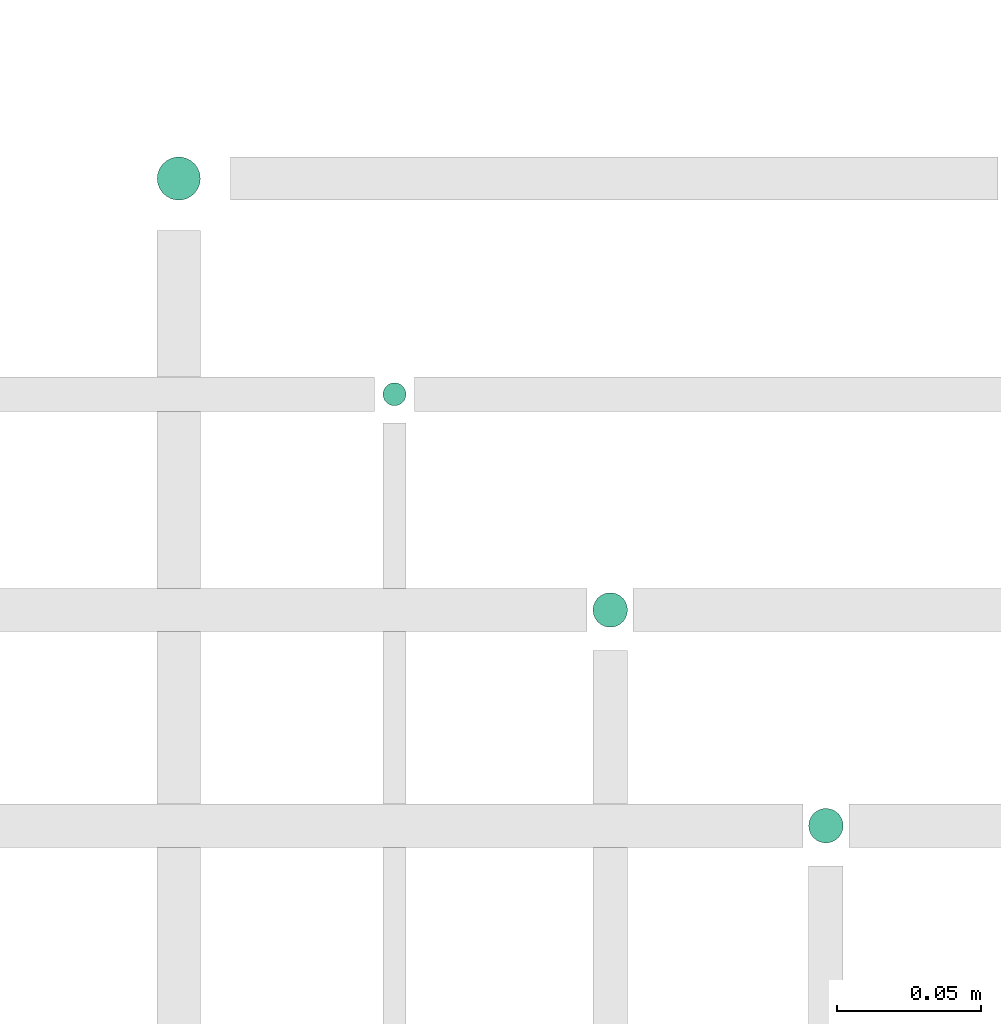
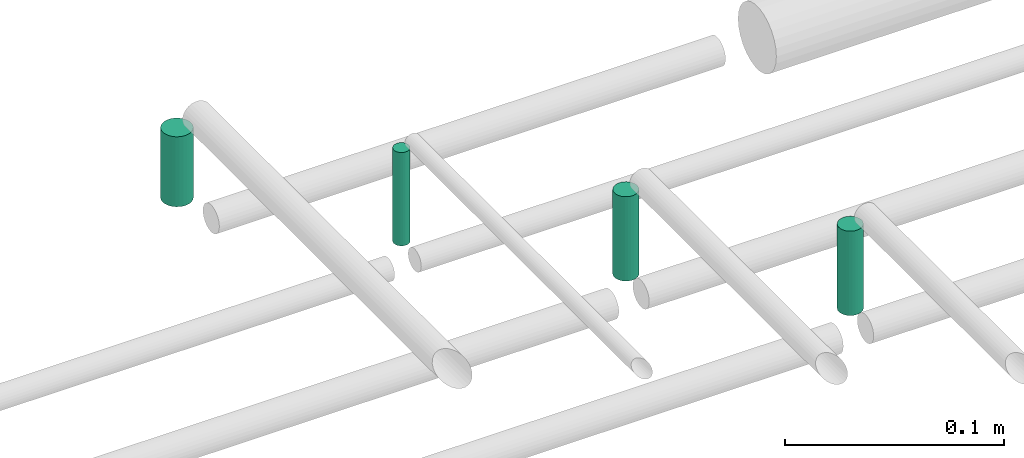
# One storey, part 55 of 65: 4 flow segments.
"""IFC2X3 building model written with IfcOpenShell, lengths in millimetres."""

from ifc_helpers import new_model, entity, si_unit, converted_unit, derived_unit, direction, frame, frame_2d, origin, origin_2d_with_axis, place, context, subcontext, project, spatial, circle, extrude, type_object, element, save


model = new_model("IFC2X3")

# Units and contexts
model_context = context("Model", 3, precision=0.01, world=origin(), true_north=direction((6.12303176911189e-17, 1.0)))
body_context = subcontext(model_context, "Body", "Model", "MODEL_VIEW")
ifc_project = project(units=[si_unit("LENGTHUNIT", "METRE", prefix="MILLI"), si_unit("AREAUNIT", "SQUARE_METRE"), si_unit("VOLUMEUNIT", "CUBIC_METRE"), converted_unit("PLANEANGLEUNIT", "DEGREE", entity("IfcRatioMeasure", 0.0174532925199433), si_unit("PLANEANGLEUNIT", "RADIAN"), dimensions=[0, 0, 0, 0, 0, 0, 0]), si_unit("MASSUNIT", "GRAM", prefix="KILO"), derived_unit("MASSDENSITYUNIT", [(si_unit("MASSUNIT", "GRAM", prefix="KILO"), 1), (si_unit("LENGTHUNIT", "METRE"), -3)]), derived_unit("MOMENTOFINERTIAUNIT", [(si_unit("LENGTHUNIT", "METRE"), 4)]), si_unit("TIMEUNIT", "SECOND"), si_unit("FREQUENCYUNIT", "HERTZ"), si_unit("THERMODYNAMICTEMPERATUREUNIT", "DEGREE_CELSIUS"), derived_unit("THERMALTRANSMITTANCEUNIT", [(si_unit("MASSUNIT", "GRAM", prefix="KILO"), 1), (si_unit("THERMODYNAMICTEMPERATUREUNIT", "KELVIN"), -1), (si_unit("TIMEUNIT", "SECOND"), -3)]), derived_unit("VOLUMETRICFLOWRATEUNIT", [(si_unit("LENGTHUNIT", "METRE"), 3), (si_unit("TIMEUNIT", "SECOND"), -1)]), derived_unit("MASSFLOWRATEUNIT", [(si_unit("MASSUNIT", "GRAM", prefix="KILO"), 1), (si_unit("TIMEUNIT", "SECOND"), -1)]), derived_unit("ROTATIONALFREQUENCYUNIT", [(si_unit("TIMEUNIT", "SECOND"), -1)]), si_unit("ELECTRICCURRENTUNIT", "AMPERE"), si_unit("ELECTRICVOLTAGEUNIT", "VOLT"), si_unit("POWERUNIT", "WATT"), si_unit("FORCEUNIT", "NEWTON", prefix="KILO"), si_unit("ILLUMINANCEUNIT", "LUX"), si_unit("LUMINOUSFLUXUNIT", "LUMEN"), si_unit("LUMINOUSINTENSITYUNIT", "CANDELA"), derived_unit("USERDEFINED", [(si_unit("MASSUNIT", "GRAM", prefix="KILO"), -1), (si_unit("LENGTHUNIT", "METRE"), -2), (si_unit("TIMEUNIT", "SECOND"), 3), (si_unit("LUMINOUSFLUXUNIT", "LUMEN"), 1)]), derived_unit("LINEARVELOCITYUNIT", [(si_unit("LENGTHUNIT", "METRE"), 1), (si_unit("TIMEUNIT", "SECOND"), -1)]), si_unit("PRESSUREUNIT", "PASCAL"), derived_unit("USERDEFINED", [(si_unit("LENGTHUNIT", "METRE"), -2), (si_unit("MASSUNIT", "GRAM", prefix="KILO"), 1), (si_unit("TIMEUNIT", "SECOND"), -2)]), derived_unit("LINEARFORCEUNIT", [(si_unit("MASSUNIT", "GRAM", prefix="KILO"), 1), (si_unit("LENGTHUNIT", "METRE"), 1), (si_unit("TIMEUNIT", "SECOND"), -2), (si_unit("LENGTHUNIT", "METRE"), -1)]), derived_unit("PLANARFORCEUNIT", [(si_unit("MASSUNIT", "GRAM", prefix="KILO"), 1), (si_unit("LENGTHUNIT", "METRE"), 1), (si_unit("TIMEUNIT", "SECOND"), -2), (si_unit("LENGTHUNIT", "METRE"), -2)])], contexts=[model_context])

# Site, building, storey
site_placement = place(None, frame((0.0, -0.00077364408347762, 0.0)))
site = spatial("IfcSite", under=ifc_project, at=site_placement, CompositionType="ELEMENT")
building_placement = place(site_placement, origin())
building = spatial("IfcBuilding", under=site, at=building_placement, CompositionType="ELEMENT")
storey_placement = place(building_placement, frame((0.0, 0.0, 19800.0)))
storey = spatial("IfcBuildingStorey", under=building, at=storey_placement, CompositionType="ELEMENT", Elevation=19800.0)

# Flow segments
pipe_segment_type = type_object("IfcPipeSegmentType", PredefinedType="NOTDEFINED")
flow_segment_1_placement = place(storey_placement, frame((50935.3052438068, 7809.40472776408, 2563.0)))
element("IfcFlowSegment", 1, at=flow_segment_1_placement, inside=storey, type_object=pipe_segment_type, context=body_context, shape_type="SweptSolid", body=[
    extrude(circle(Radius=4.0, at=frame_2d((0.0, -1.08286712929839e-12), x_axis=(1.0, 0.0))), frame((5.59527223591499, 5.59527223591499, 0.0), z_axis=(0.0, 0.0, 1.0), x_axis=(-1.0, 0.0, 0.0)), (0.0, 0.0, 1.0), 52.0000000000055),
])
flow_segment_2_placement = place(storey_placement, frame((51008.3052438068, 7732.40472776408, 2564.0)))
element("IfcFlowSegment", 2, at=flow_segment_2_placement, inside=storey, type_object=pipe_segment_type, context=body_context, shape_type="SweptSolid", body=[
    extrude(circle(Radius=6.0, at=frame_2d((0.0, -1.08286712929839e-12), x_axis=(1.0, 0.0))), frame((7.59527223591454, 7.59527223591454, 0.0), z_axis=(0.0, 0.0, 1.0), x_axis=(-1.0, 0.0, 0.0)), (0.0, 0.0, 1.0), 47.0000000000023),
])
flow_segment_3_placement = place(storey_placement, frame((51083.3052438068, 7657.40472776409, 2564.0)))
element("IfcFlowSegment", 3, at=flow_segment_3_placement, inside=storey, type_object=pipe_segment_type, context=body_context, shape_type="SweptSolid", body=[
    extrude(circle(Radius=6.0, at=origin_2d_with_axis()), frame((7.59527223591454, 7.59527223591562, 0.0), z_axis=(0.0, 0.0, 1.0), x_axis=(-1.0, 0.0, 0.0)), (0.0, 0.0, 1.0), 47.0000000000023),
])
flow_segment_4_placement = place(storey_placement, frame((50856.8052438068, 7880.90472776415, 2568.0)))
element("IfcFlowSegment", 4, at=flow_segment_4_placement, inside=storey, type_object=pipe_segment_type, context=body_context, shape_type="SweptSolid", body=[
    extrude(circle(Radius=7.5, at=origin_2d_with_axis()), frame((9.09527223591419, 9.09527223591636, 0.0), z_axis=(0.0, 0.0, 1.0), x_axis=(-1.0, 0.0, 0.0)), (0.0, 0.0, 1.0), 39.0000000000215),
])

save(model, "model.ifc")
